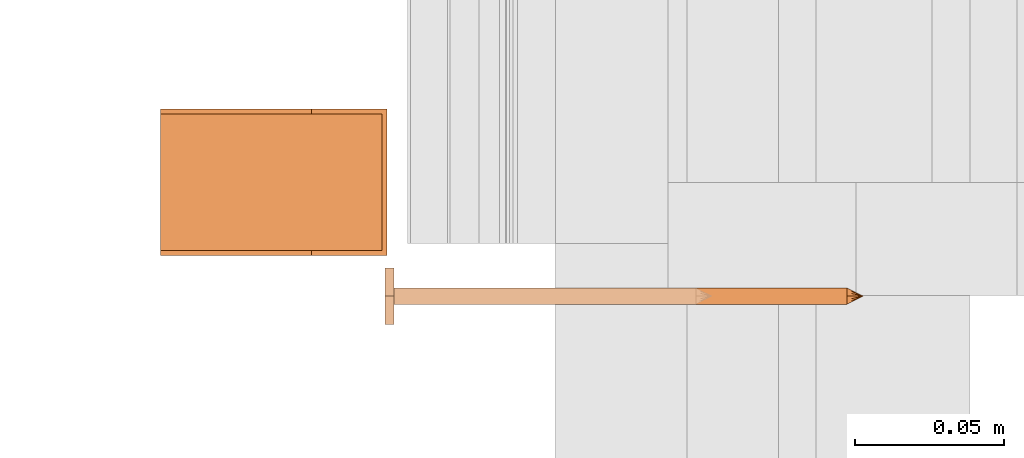
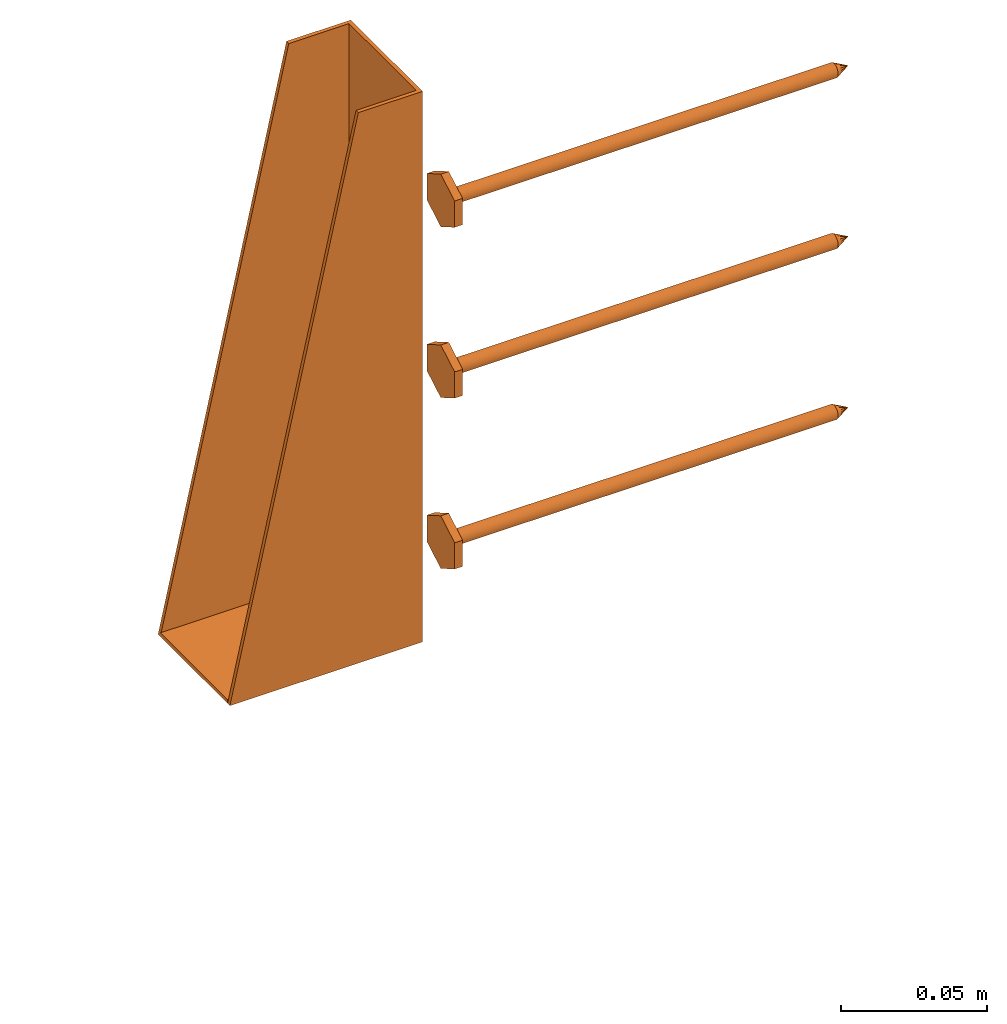
# One storey, part 18 of 44: 4 proxies.
"""IFC4 building model written with IfcOpenShell, lengths in feet."""

from ifc_helpers import new_model, entity, si_unit, converted_unit, derived_unit, direction, frame, frame_2d, origin, origin_2d_with_axis, place, context, subcontext, project, spatial, polyline, rectangle, outline, extrude, source, transform, mapped, material, type_object, type_shapes, element, save


model = new_model("IFC4")

# Units and contexts
model_context = context("Model", 3, precision=0.0001, world=origin(), true_north=direction((6.12303176911189e-17, 1.0)))
body_context = subcontext(model_context, "Body", "Model", "MODEL_VIEW")
ifc_project = project(units=[converted_unit("LENGTHUNIT", "FOOT", entity("IfcRatioMeasure", 0.3048), si_unit("LENGTHUNIT", "METRE"), dimensions=[1, 0, 0, 0, 0, 0, 0]), converted_unit("AREAUNIT", "SQUARE FOOT", entity("IfcRatioMeasure", 0.09290304), si_unit("AREAUNIT", "SQUARE_METRE"), dimensions=[2, 0, 0, 0, 0, 0, 0]), converted_unit("VOLUMEUNIT", "CUBIC FOOT", entity("IfcRatioMeasure", 0.028316846592), si_unit("VOLUMEUNIT", "CUBIC_METRE"), dimensions=[3, 0, 0, 0, 0, 0, 0]), converted_unit("PLANEANGLEUNIT", "DEGREE", entity("IfcRatioMeasure", 0.0174532925199433), si_unit("PLANEANGLEUNIT", "RADIAN"), dimensions=[0, 0, 0, 0, 0, 0, 0]), si_unit("MASSUNIT", "GRAM", prefix="KILO"), derived_unit("MASSDENSITYUNIT", [(si_unit("MASSUNIT", "GRAM", prefix="KILO"), 1), (si_unit("LENGTHUNIT", "METRE"), -3)]), derived_unit("MOMENTOFINERTIAUNIT", [(si_unit("LENGTHUNIT", "METRE"), 4)]), si_unit("TIMEUNIT", "SECOND"), si_unit("FREQUENCYUNIT", "HERTZ"), si_unit("THERMODYNAMICTEMPERATUREUNIT", "DEGREE_CELSIUS"), derived_unit("THERMALTRANSMITTANCEUNIT", [(si_unit("MASSUNIT", "GRAM", prefix="KILO"), 1), (si_unit("THERMODYNAMICTEMPERATUREUNIT", "KELVIN"), -1), (si_unit("TIMEUNIT", "SECOND"), -3)]), derived_unit("VOLUMETRICFLOWRATEUNIT", [(si_unit("LENGTHUNIT", "METRE"), 3), (si_unit("TIMEUNIT", "SECOND"), -1)]), si_unit("ELECTRICCURRENTUNIT", "AMPERE"), si_unit("ELECTRICVOLTAGEUNIT", "VOLT"), si_unit("POWERUNIT", "WATT"), si_unit("FORCEUNIT", "NEWTON"), si_unit("ILLUMINANCEUNIT", "LUX"), si_unit("LUMINOUSFLUXUNIT", "LUMEN"), si_unit("LUMINOUSINTENSITYUNIT", "CANDELA"), derived_unit("USERDEFINED", [(si_unit("MASSUNIT", "GRAM", prefix="KILO"), -1), (si_unit("LENGTHUNIT", "METRE"), -2), (si_unit("TIMEUNIT", "SECOND"), 3), (si_unit("LUMINOUSFLUXUNIT", "LUMEN"), 1)]), derived_unit("LINEARVELOCITYUNIT", [(si_unit("LENGTHUNIT", "METRE"), 1), (si_unit("TIMEUNIT", "SECOND"), -1)]), si_unit("PRESSUREUNIT", "PASCAL"), derived_unit("USERDEFINED", [(si_unit("LENGTHUNIT", "METRE"), -2), (si_unit("MASSUNIT", "GRAM", prefix="KILO"), 1), (si_unit("TIMEUNIT", "SECOND"), -2)]), derived_unit("LINEARFORCEUNIT", [(si_unit("MASSUNIT", "GRAM", prefix="KILO"), 1), (si_unit("LENGTHUNIT", "METRE"), 1), (si_unit("TIMEUNIT", "SECOND"), -2), (si_unit("LENGTHUNIT", "METRE"), -1)]), derived_unit("PLANARFORCEUNIT", [(si_unit("MASSUNIT", "GRAM", prefix="KILO"), 1), (si_unit("LENGTHUNIT", "METRE"), 1), (si_unit("TIMEUNIT", "SECOND"), -2), (si_unit("LENGTHUNIT", "METRE"), -2)])], contexts=[model_context])

# Site, building, storey
site_placement = place(None, origin())
site = spatial("IfcSite", under=ifc_project, at=site_placement, CompositionType="ELEMENT")
building_placement = place(site_placement, origin())
building = spatial("IfcBuilding", under=site, at=building_placement, CompositionType="ELEMENT")
storey_placement = place(building_placement, origin())
storey = spatial("IfcBuildingStorey", under=building, at=storey_placement, CompositionType="ELEMENT", Elevation=0.0)

# Proxies
ifc_material_1 = material(Name="HUC46 JOIST HANGER WITH CONCEALED HDG - UNPAINTED", Category="Materials")
building_element_proxy_type_1 = type_object("IfcBuildingElementProxyType", Name="050523 - Metal Joist Hanger - Generic:1.81/9-SDS", PredefinedType="NOTDEFINED", material=ifc_material_1)
shared_shape_1 = source(origin(), body_context, "Body", "SweptSolid", [
    extrude(outline(polyline([(-0.377604166666657, -0.0833333333333589), (0.377604166666657, -0.0833333333333589), (0.377604166666657, 0.0), (-0.377604166666657, 0.166666666666694), (-0.377604166666657, -0.0833333333333589)])), frame((-0.0807291666666463, -0.0833333333333328, 0.372395833333338), z_axis=(1.0, 0.0, 0.0), x_axis=(0.0, 0.0, 1.0)), (0.0, 0.0, 1.0), 0.00520833333333333),
    extrude(outline(polyline([(-0.377604166666661, -0.0833333333333546), (0.377604166666661, -0.0833333333333546), (0.377604166666661, 0.0), (-0.377604166666661, 0.166666666666692), (-0.377604166666661, -0.0833333333333546)])), frame((0.0755208333333537, -0.0833333333333374, 0.372395833333333), z_axis=(1.0, 0.0, 0.0), x_axis=(0.0, 0.0, 1.0)), (0.0, 0.0, 1.0), 0.00520833333333333),
    extrude(rectangle(XDim=0.00520833333329789, YDim=0.104166666666653, at=origin_2d_with_axis()), frame((0.0234375000000141, -0.00260416666671204, 0.0), z_axis=(0.0, 0.0, 1.0), x_axis=(0.0, 1.0, 0.0)), (0.0, 0.0, 1.0), 0.750000000000093),
    extrude(rectangle(XDim=0.00520833333329789, YDim=0.104166666666656, at=origin_2d_with_axis()), frame((-0.0234375000000063, -0.00260416666671204, 0.0), z_axis=(0.0, 0.0, 1.0), x_axis=(0.0, 1.0, 0.0)), (0.0, 0.0, 1.0), 0.750000000000097),
    extrude(rectangle(XDim=0.250000000000316, YDim=0.151041666666731, at=frame_2d((-2.77555756156289e-17, -6.93889390390723e-18), x_axis=(1.0, 0.0))), frame((0.0, -0.125000000000474, -0.00520833333333946), z_axis=(0.0, 0.0, 1.0), x_axis=(0.0, -1.0, 0.0)), (0.0, 0.0, 1.0), 0.00520833333333333),
])
type_shapes(building_element_proxy_type_1, [shared_shape_1])
proxy_placement = place(storey_placement, frame((1459.12506713878, 2.06770833332918, 31.2083333333288), z_axis=(0.0, 0.0, 1.0), x_axis=(0.0, -1.0, 0.0)))
element("IfcBuildingElementProxy", 1, at=proxy_placement, inside=storey, type_object=building_element_proxy_type_1, material=ifc_material_1, Name="050523 - Metal Joist Hanger - Generic:1.81/9", ObjectType="050523 - Metal Joist Hanger - Generic:1.81/9-SDS", PredefinedType="NOTDEFINED", context=body_context, shape_type="MappedRepresentation", body=[
    mapped(shared_shape_1, transform((0.0, 0.0, 0.0), scale=1.0)),
])
ifc_material_2 = material(Name="STRONG-DRIVE TIMBER SCREW (EXTERIOR GRADE)", Category="Materials")
building_element_proxy_type_2 = type_object("IfcBuildingElementProxyType", PredefinedType="NOTDEFINED", material=ifc_material_2)
cartesian_point_1 = entity("IfcCartesianPoint", [0.0, -0.00916666666678086, -0.499999999999898])
vertex_point_1 = entity("IfcVertexPoint", cartesian_point_1)
cartesian_point_2 = entity("IfcCartesianPoint", [0.0, 0.00916666666667654, -0.499999999999898])
vertex_point_2 = entity("IfcVertexPoint", cartesian_point_2)
cartesian_point_3 = entity("IfcCartesianPoint", [0.0, 0.0, -0.499999999999898])
ifc_direction_1 = entity("IfcDirection", [0.0, 0.0, 1.0])
ifc_direction_2 = entity("IfcDirection", [0.0, 1.0, 0.0])
edge_curve_1 = entity("IfcEdgeCurve", vertex_point_1, vertex_point_2, entity("IfcTrimmedCurve", entity("IfcCircle", entity("IfcAxis2Placement3D", cartesian_point_3, ifc_direction_1, ifc_direction_2), 0.0091666666667287), [cartesian_point_1], [cartesian_point_2], True, "CARTESIAN"), True)
vertex_point_3 = entity("IfcVertexPoint", cartesian_point_3)
ifc_direction_3 = entity("IfcDirection", [0.0, -1.0, 0.0])
edge_curve_2 = entity("IfcEdgeCurve", vertex_point_2, vertex_point_3, entity("IfcTrimmedCurve", entity("IfcLine", cartesian_point_2, entity("IfcVector", ifc_direction_3, 1.0)), [cartesian_point_2], [cartesian_point_3], True, "CARTESIAN"), True)
edge_curve_3 = entity("IfcEdgeCurve", vertex_point_3, vertex_point_1, entity("IfcTrimmedCurve", entity("IfcLine", cartesian_point_3, entity("IfcVector", ifc_direction_3, 1.0)), [cartesian_point_3], [cartesian_point_1], True, "CARTESIAN"), True)
edge_curve_4 = entity("IfcEdgeCurve", vertex_point_2, vertex_point_1, entity("IfcTrimmedCurve", entity("IfcCircle", entity("IfcAxis2Placement3D", cartesian_point_3, ifc_direction_1, ifc_direction_2), 0.0091666666667287), [cartesian_point_2], [cartesian_point_1], True, "CARTESIAN"), True)
cartesian_point_4 = entity("IfcCartesianPoint", [0.0, 0.0, -0.518333333333])
vertex_point_4 = entity("IfcVertexPoint", cartesian_point_4)
edge_curve_5 = entity("IfcEdgeCurve", vertex_point_4, vertex_point_2, entity("IfcTrimmedCurve", entity("IfcLine", cartesian_point_4, entity("IfcVector", entity("IfcDirection", [0.0, 0.447213595507238, 0.894427190996276]), 1.0)), [cartesian_point_4], [cartesian_point_2], True, "CARTESIAN"), True)
edge_curve_6 = entity("IfcEdgeCurve", vertex_point_1, vertex_point_4, entity("IfcTrimmedCurve", entity("IfcLine", cartesian_point_1, entity("IfcVector", entity("IfcDirection", [0.0, 0.447213595507224, -0.894427190996283]), 1.0)), [cartesian_point_1], [cartesian_point_4], True, "CARTESIAN"), True)
cartesian_point_5 = entity("IfcCartesianPoint", [-0.00916666666669726, 0.0, -0.499999999999898])
cartesian_point_6 = entity("IfcCartesianPoint", [0.0, 0.0, -0.504868851257523])
ifc_direction_4 = entity("IfcDirection", [0.0, 0.0, -1.0])
cartesian_point_7 = entity("IfcCartesianPoint", [-0.0312499999999625, 0.0180421959120341, 0.0104166666670403])
vertex_point_5 = entity("IfcVertexPoint", cartesian_point_7)
cartesian_point_8 = entity("IfcCartesianPoint", [-0.0312499999999625, -0.0180421959123371, 0.0104166666670405])
vertex_point_6 = entity("IfcVertexPoint", cartesian_point_8)
ifc_direction_5 = entity("IfcDirection", [0.0, -1.0, 0.0])
edge_curve_7 = entity("IfcEdgeCurve", vertex_point_5, vertex_point_6, entity("IfcTrimmedCurve", entity("IfcLine", cartesian_point_7, entity("IfcVector", ifc_direction_5, 1.0)), [cartesian_point_7], [cartesian_point_8], True, "CARTESIAN"), True)
cartesian_point_9 = entity("IfcCartesianPoint", [0.0, -0.0360843918245031, 0.0104166666670406])
vertex_point_7 = entity("IfcVertexPoint", cartesian_point_9)
edge_curve_8 = entity("IfcEdgeCurve", vertex_point_6, vertex_point_7, entity("IfcTrimmedCurve", entity("IfcLine", cartesian_point_8, entity("IfcVector", entity("IfcDirection", [0.866025403784438, -0.500000000000001, 0.0]), 1.0)), [cartesian_point_8], [cartesian_point_9], True, "CARTESIAN"), True)
cartesian_point_10 = entity("IfcCartesianPoint", [0.0312500000000785, -0.0180421959122939, 0.0104166666670405])
vertex_point_8 = entity("IfcVertexPoint", cartesian_point_10)
edge_curve_9 = entity("IfcEdgeCurve", vertex_point_7, vertex_point_8, entity("IfcTrimmedCurve", entity("IfcLine", cartesian_point_9, entity("IfcVector", entity("IfcDirection", [0.86602540378444, 0.499999999999998, 0.0]), 1.0)), [cartesian_point_9], [cartesian_point_10], True, "CARTESIAN"), True)
cartesian_point_11 = entity("IfcCartesianPoint", [0.0312500000000786, 0.0180421959119906, 0.0104166666670403])
vertex_point_9 = entity("IfcVertexPoint", cartesian_point_11)
ifc_direction_6 = entity("IfcDirection", [0.0, 1.0, 0.0])
edge_curve_10 = entity("IfcEdgeCurve", vertex_point_8, vertex_point_9, entity("IfcTrimmedCurve", entity("IfcLine", cartesian_point_10, entity("IfcVector", ifc_direction_6, 1.0)), [cartesian_point_10], [cartesian_point_11], True, "CARTESIAN"), True)
cartesian_point_12 = entity("IfcCartesianPoint", [0.0, 0.0360843918242001, 0.0104166666670402])
vertex_point_10 = entity("IfcVertexPoint", cartesian_point_12)
edge_curve_11 = entity("IfcEdgeCurve", vertex_point_9, vertex_point_10, entity("IfcTrimmedCurve", entity("IfcLine", cartesian_point_11, entity("IfcVector", entity("IfcDirection", [-0.866025403784436, 0.500000000000004, 0.0]), 1.0)), [cartesian_point_11], [cartesian_point_12], True, "CARTESIAN"), True)
edge_curve_12 = entity("IfcEdgeCurve", vertex_point_10, vertex_point_5, entity("IfcTrimmedCurve", entity("IfcLine", cartesian_point_12, entity("IfcVector", entity("IfcDirection", [-0.866025403784438, -0.500000000000001, 0.0]), 1.0)), [cartesian_point_12], [cartesian_point_7], True, "CARTESIAN"), True)
ifc_direction_7 = entity("IfcDirection", [0.0, 0.0, 1.0])
cartesian_point_13 = entity("IfcCartesianPoint", [-0.0312499999999625, 0.018042195912034, 0.0])
vertex_point_11 = entity("IfcVertexPoint", cartesian_point_13)
cartesian_point_14 = entity("IfcCartesianPoint", [0.0, 0.0360843918242001, 0.0])
vertex_point_12 = entity("IfcVertexPoint", cartesian_point_14)
edge_curve_13 = entity("IfcEdgeCurve", vertex_point_11, vertex_point_12, entity("IfcTrimmedCurve", entity("IfcLine", cartesian_point_13, entity("IfcVector", entity("IfcDirection", [0.866025403784438, 0.500000000000001, 0.0]), 1.0)), [cartesian_point_13], [cartesian_point_14], True, "CARTESIAN"), True)
cartesian_point_15 = entity("IfcCartesianPoint", [0.0312500000000786, 0.0180421959119905, 0.0])
vertex_point_13 = entity("IfcVertexPoint", cartesian_point_15)
edge_curve_14 = entity("IfcEdgeCurve", vertex_point_12, vertex_point_13, entity("IfcTrimmedCurve", entity("IfcLine", cartesian_point_14, entity("IfcVector", entity("IfcDirection", [0.866025403784437, -0.500000000000004, 0.0]), 1.0)), [cartesian_point_14], [cartesian_point_15], True, "CARTESIAN"), True)
cartesian_point_16 = entity("IfcCartesianPoint", [0.0312500000000785, -0.0180421959122939, 0.0])
vertex_point_14 = entity("IfcVertexPoint", cartesian_point_16)
edge_curve_15 = entity("IfcEdgeCurve", vertex_point_13, vertex_point_14, entity("IfcTrimmedCurve", entity("IfcLine", cartesian_point_15, entity("IfcVector", ifc_direction_5, 1.0)), [cartesian_point_15], [cartesian_point_16], True, "CARTESIAN"), True)
cartesian_point_17 = entity("IfcCartesianPoint", [0.0, -0.0360843918245032, 0.0])
vertex_point_15 = entity("IfcVertexPoint", cartesian_point_17)
edge_curve_16 = entity("IfcEdgeCurve", vertex_point_14, vertex_point_15, entity("IfcTrimmedCurve", entity("IfcLine", cartesian_point_16, entity("IfcVector", entity("IfcDirection", [-0.86602540378444, -0.499999999999998, 0.0]), 1.0)), [cartesian_point_16], [cartesian_point_17], True, "CARTESIAN"), True)
cartesian_point_18 = entity("IfcCartesianPoint", [-0.0312499999999625, -0.0180421959123372, 0.0])
vertex_point_16 = entity("IfcVertexPoint", cartesian_point_18)
edge_curve_17 = entity("IfcEdgeCurve", vertex_point_15, vertex_point_16, entity("IfcTrimmedCurve", entity("IfcLine", cartesian_point_17, entity("IfcVector", entity("IfcDirection", [-0.866025403784438, 0.500000000000001, 0.0]), 1.0)), [cartesian_point_17], [cartesian_point_18], True, "CARTESIAN"), True)
edge_curve_18 = entity("IfcEdgeCurve", vertex_point_16, vertex_point_11, entity("IfcTrimmedCurve", entity("IfcLine", cartesian_point_18, entity("IfcVector", ifc_direction_6, 1.0)), [cartesian_point_18], [cartesian_point_13], True, "CARTESIAN"), True)
ifc_direction_8 = entity("IfcDirection", [0.0, 0.0, -1.0])
edge_curve_19 = entity("IfcEdgeCurve", vertex_point_5, vertex_point_11, entity("IfcTrimmedCurve", entity("IfcLine", cartesian_point_7, entity("IfcVector", ifc_direction_8, 1.0)), [cartesian_point_7], [cartesian_point_13], True, "CARTESIAN"), True)
edge_curve_20 = entity("IfcEdgeCurve", vertex_point_16, vertex_point_6, entity("IfcTrimmedCurve", entity("IfcLine", cartesian_point_8, entity("IfcVector", ifc_direction_7, 1.0)), [cartesian_point_18], [cartesian_point_8], True, "CARTESIAN"), True)
edge_curve_21 = entity("IfcEdgeCurve", vertex_point_15, vertex_point_7, entity("IfcTrimmedCurve", entity("IfcLine", cartesian_point_9, entity("IfcVector", ifc_direction_7, 1.0)), [cartesian_point_17], [cartesian_point_9], True, "CARTESIAN"), True)
edge_curve_22 = entity("IfcEdgeCurve", vertex_point_14, vertex_point_8, entity("IfcTrimmedCurve", entity("IfcLine", cartesian_point_10, entity("IfcVector", ifc_direction_7, 1.0)), [cartesian_point_16], [cartesian_point_10], True, "CARTESIAN"), True)
edge_curve_23 = entity("IfcEdgeCurve", vertex_point_13, vertex_point_9, entity("IfcTrimmedCurve", entity("IfcLine", cartesian_point_11, entity("IfcVector", ifc_direction_7, 1.0)), [cartesian_point_15], [cartesian_point_11], True, "CARTESIAN"), True)
edge_curve_24 = entity("IfcEdgeCurve", vertex_point_12, vertex_point_10, entity("IfcTrimmedCurve", entity("IfcLine", cartesian_point_12, entity("IfcVector", ifc_direction_7, 1.0)), [cartesian_point_14], [cartesian_point_12], True, "CARTESIAN"), True)
cartesian_point_19 = entity("IfcCartesianPoint", [0.0, -0.00916666666682102, 0.0])
vertex_point_17 = entity("IfcVertexPoint", cartesian_point_19)
cartesian_point_20 = entity("IfcCartesianPoint", [0.0, 0.00916666666651231, 0.0])
vertex_point_18 = entity("IfcVertexPoint", cartesian_point_20)
cartesian_point_21 = entity("IfcCartesianPoint", [0.0, 0.0, 0.0])
ifc_direction_9 = entity("IfcDirection", [0.0, 0.0, 1.0])
ifc_direction_10 = entity("IfcDirection", [0.0, 1.0, 0.0])
edge_curve_25 = entity("IfcEdgeCurve", vertex_point_17, vertex_point_18, entity("IfcTrimmedCurve", entity("IfcCircle", entity("IfcAxis2Placement3D", cartesian_point_21, ifc_direction_9, ifc_direction_10), 0.00916666666666667), [cartesian_point_19], [cartesian_point_20], True, "CARTESIAN"), True)
edge_curve_26 = entity("IfcEdgeCurve", vertex_point_18, vertex_point_17, entity("IfcTrimmedCurve", entity("IfcCircle", entity("IfcAxis2Placement3D", cartesian_point_21, ifc_direction_9, ifc_direction_10), 0.00916666666666667), [cartesian_point_20], [cartesian_point_19], True, "CARTESIAN"), True)
cartesian_point_22 = entity("IfcCartesianPoint", [0.0, -0.00916666666682533, -0.500000000000006])
vertex_point_19 = entity("IfcVertexPoint", cartesian_point_22)
cartesian_point_23 = entity("IfcCartesianPoint", [0.0, 0.00916666666650801, -0.500000000000006])
vertex_point_20 = entity("IfcVertexPoint", cartesian_point_23)
cartesian_point_24 = entity("IfcCartesianPoint", [0.0, 0.0, -0.500000000000006])
ifc_direction_11 = entity("IfcDirection", [0.0, 0.0, -1.0])
edge_curve_27 = entity("IfcEdgeCurve", vertex_point_19, vertex_point_20, entity("IfcTrimmedCurve", entity("IfcCircle", entity("IfcAxis2Placement3D", cartesian_point_24, ifc_direction_11, ifc_direction_10), 0.00916666666666667), [cartesian_point_22], [cartesian_point_23], True, "CARTESIAN"), True)
edge_curve_28 = entity("IfcEdgeCurve", vertex_point_20, vertex_point_19, entity("IfcTrimmedCurve", entity("IfcCircle", entity("IfcAxis2Placement3D", cartesian_point_24, ifc_direction_11, ifc_direction_10), 0.00916666666666667), [cartesian_point_23], [cartesian_point_22], True, "CARTESIAN"), True)
edge_curve_29 = entity("IfcEdgeCurve", vertex_point_17, vertex_point_19, entity("IfcTrimmedCurve", entity("IfcLine", cartesian_point_19, entity("IfcVector", ifc_direction_11, 1.0)), [cartesian_point_19], [cartesian_point_22], True, "CARTESIAN"), True)
edge_curve_30 = entity("IfcEdgeCurve", vertex_point_20, vertex_point_18, entity("IfcTrimmedCurve", entity("IfcLine", cartesian_point_20, entity("IfcVector", ifc_direction_9, 1.0)), [cartesian_point_23], [cartesian_point_20], True, "CARTESIAN"), True)
shared_shape_2 = source(origin(), body_context, "Body", "AdvancedBrep", [
    entity("IfcAdvancedBrep", entity("IfcClosedShell", [entity("IfcAdvancedFace", [entity("IfcFaceOuterBound", entity("IfcEdgeLoop", [entity("IfcOrientedEdge", None, None, edge_curve_1, True), entity("IfcOrientedEdge", None, None, edge_curve_2, True), entity("IfcOrientedEdge", None, None, edge_curve_3, True)]), True)], entity("IfcPlane", entity("IfcAxis2Placement3D", cartesian_point_3, ifc_direction_1, ifc_direction_2)), True), entity("IfcAdvancedFace", [entity("IfcFaceOuterBound", entity("IfcEdgeLoop", [entity("IfcOrientedEdge", None, None, edge_curve_4, True), entity("IfcOrientedEdge", None, None, edge_curve_3, False), entity("IfcOrientedEdge", None, None, edge_curve_2, False)]), True)], entity("IfcPlane", entity("IfcAxis2Placement3D", cartesian_point_3, ifc_direction_1, ifc_direction_2)), True), entity("IfcAdvancedFace", [entity("IfcFaceOuterBound", entity("IfcEdgeLoop", [entity("IfcOrientedEdge", None, None, edge_curve_5, True), entity("IfcOrientedEdge", None, None, edge_curve_1, False), entity("IfcOrientedEdge", None, None, edge_curve_6, True)]), True)], entity("IfcSurfaceOfRevolution", entity("IfcArbitraryOpenProfileDef", "CURVE", None, entity("IfcTrimmedCurve", entity("IfcLine", cartesian_point_4, entity("IfcVector", entity("IfcDirection", [0.447213595507221, 0.0, -0.894427190996284]), 1.0)), [cartesian_point_5], [cartesian_point_4], True, "CARTESIAN")), None, entity("IfcAxis1Placement", cartesian_point_6, ifc_direction_4)), True), entity("IfcAdvancedFace", [entity("IfcFaceOuterBound", entity("IfcEdgeLoop", [entity("IfcOrientedEdge", None, None, edge_curve_6, False), entity("IfcOrientedEdge", None, None, edge_curve_4, False), entity("IfcOrientedEdge", None, None, edge_curve_5, False)]), True)], entity("IfcSurfaceOfRevolution", entity("IfcArbitraryOpenProfileDef", "CURVE", None, entity("IfcTrimmedCurve", entity("IfcLine", cartesian_point_4, entity("IfcVector", entity("IfcDirection", [0.447213595507221, 0.0, -0.894427190996284]), 1.0)), [cartesian_point_5], [cartesian_point_4], True, "CARTESIAN")), None, entity("IfcAxis1Placement", cartesian_point_6, ifc_direction_4)), True)])),
    entity("IfcAdvancedBrep", entity("IfcClosedShell", [entity("IfcAdvancedFace", [entity("IfcFaceOuterBound", entity("IfcEdgeLoop", [entity("IfcOrientedEdge", None, None, edge_curve_7, True), entity("IfcOrientedEdge", None, None, edge_curve_8, True), entity("IfcOrientedEdge", None, None, edge_curve_9, True), entity("IfcOrientedEdge", None, None, edge_curve_10, True), entity("IfcOrientedEdge", None, None, edge_curve_11, True), entity("IfcOrientedEdge", None, None, edge_curve_12, True)]), True)], entity("IfcPlane", entity("IfcAxis2Placement3D", cartesian_point_7, ifc_direction_7, ifc_direction_5)), True), entity("IfcAdvancedFace", [entity("IfcFaceOuterBound", entity("IfcEdgeLoop", [entity("IfcOrientedEdge", None, None, edge_curve_13, True), entity("IfcOrientedEdge", None, None, edge_curve_14, True), entity("IfcOrientedEdge", None, None, edge_curve_15, True), entity("IfcOrientedEdge", None, None, edge_curve_16, True), entity("IfcOrientedEdge", None, None, edge_curve_17, True), entity("IfcOrientedEdge", None, None, edge_curve_18, True)]), True)], entity("IfcPlane", entity("IfcAxis2Placement3D", cartesian_point_13, ifc_direction_8, ifc_direction_6)), True), entity("IfcAdvancedFace", [entity("IfcFaceOuterBound", entity("IfcEdgeLoop", [entity("IfcOrientedEdge", None, None, edge_curve_7, False), entity("IfcOrientedEdge", None, None, edge_curve_19, True), entity("IfcOrientedEdge", None, None, edge_curve_18, False), entity("IfcOrientedEdge", None, None, edge_curve_20, True)]), True)], entity("IfcPlane", entity("IfcAxis2Placement3D", cartesian_point_7, entity("IfcDirection", [-1.0, 0.0, 0.0]), ifc_direction_8)), True), entity("IfcAdvancedFace", [entity("IfcFaceOuterBound", entity("IfcEdgeLoop", [entity("IfcOrientedEdge", None, None, edge_curve_8, False), entity("IfcOrientedEdge", None, None, edge_curve_20, False), entity("IfcOrientedEdge", None, None, edge_curve_17, False), entity("IfcOrientedEdge", None, None, edge_curve_21, True)]), True)], entity("IfcPlane", entity("IfcAxis2Placement3D", cartesian_point_8, entity("IfcDirection", [-0.500000000000001, -0.866025403784438, 0.0]), ifc_direction_8)), True), entity("IfcAdvancedFace", [entity("IfcFaceOuterBound", entity("IfcEdgeLoop", [entity("IfcOrientedEdge", None, None, edge_curve_9, False), entity("IfcOrientedEdge", None, None, edge_curve_21, False), entity("IfcOrientedEdge", None, None, edge_curve_16, False), entity("IfcOrientedEdge", None, None, edge_curve_22, True)]), True)], entity("IfcPlane", entity("IfcAxis2Placement3D", cartesian_point_9, entity("IfcDirection", [0.499999999999998, -0.86602540378444, 0.0]), ifc_direction_8)), True), entity("IfcAdvancedFace", [entity("IfcFaceOuterBound", entity("IfcEdgeLoop", [entity("IfcOrientedEdge", None, None, edge_curve_10, False), entity("IfcOrientedEdge", None, None, edge_curve_22, False), entity("IfcOrientedEdge", None, None, edge_curve_15, False), entity("IfcOrientedEdge", None, None, edge_curve_23, True)]), True)], entity("IfcPlane", entity("IfcAxis2Placement3D", cartesian_point_10, entity("IfcDirection", [1.0, 0.0, 0.0]), ifc_direction_8)), True), entity("IfcAdvancedFace", [entity("IfcFaceOuterBound", entity("IfcEdgeLoop", [entity("IfcOrientedEdge", None, None, edge_curve_11, False), entity("IfcOrientedEdge", None, None, edge_curve_23, False), entity("IfcOrientedEdge", None, None, edge_curve_14, False), entity("IfcOrientedEdge", None, None, edge_curve_24, True)]), True)], entity("IfcPlane", entity("IfcAxis2Placement3D", cartesian_point_11, entity("IfcDirection", [0.500000000000003, 0.866025403784437, 0.0]), ifc_direction_8)), True), entity("IfcAdvancedFace", [entity("IfcFaceOuterBound", entity("IfcEdgeLoop", [entity("IfcOrientedEdge", None, None, edge_curve_12, False), entity("IfcOrientedEdge", None, None, edge_curve_24, False), entity("IfcOrientedEdge", None, None, edge_curve_13, False), entity("IfcOrientedEdge", None, None, edge_curve_19, False)]), True)], entity("IfcPlane", entity("IfcAxis2Placement3D", cartesian_point_12, entity("IfcDirection", [-0.500000000000001, 0.866025403784438, 0.0]), ifc_direction_8)), True)])),
    entity("IfcAdvancedBrep", entity("IfcClosedShell", [entity("IfcAdvancedFace", [entity("IfcFaceOuterBound", entity("IfcEdgeLoop", [entity("IfcOrientedEdge", None, None, edge_curve_25, True), entity("IfcOrientedEdge", None, None, edge_curve_26, True)]), True)], entity("IfcPlane", entity("IfcAxis2Placement3D", cartesian_point_20, ifc_direction_9, entity("IfcDirection", [-1.0, 0.0, 0.0]))), True), entity("IfcAdvancedFace", [entity("IfcFaceOuterBound", entity("IfcEdgeLoop", [entity("IfcOrientedEdge", None, None, edge_curve_27, True), entity("IfcOrientedEdge", None, None, edge_curve_28, True)]), True)], entity("IfcPlane", entity("IfcAxis2Placement3D", cartesian_point_23, ifc_direction_11, entity("IfcDirection", [1.0, 0.0, 0.0]))), True), entity("IfcAdvancedFace", [entity("IfcFaceOuterBound", entity("IfcEdgeLoop", [entity("IfcOrientedEdge", None, None, edge_curve_25, False), entity("IfcOrientedEdge", None, None, edge_curve_29, True), entity("IfcOrientedEdge", None, None, edge_curve_28, False), entity("IfcOrientedEdge", None, None, edge_curve_30, True)]), True)], entity("IfcCylindricalSurface", entity("IfcAxis2Placement3D", cartesian_point_24, ifc_direction_9, ifc_direction_10), 0.00916666666666667), True), entity("IfcAdvancedFace", [entity("IfcFaceOuterBound", entity("IfcEdgeLoop", [entity("IfcOrientedEdge", None, None, edge_curve_26, False), entity("IfcOrientedEdge", None, None, edge_curve_30, False), entity("IfcOrientedEdge", None, None, edge_curve_27, False), entity("IfcOrientedEdge", None, None, edge_curve_29, False)]), True)], entity("IfcCylindricalSurface", entity("IfcAxis2Placement3D", cartesian_point_24, ifc_direction_9, ifc_direction_10), 0.00916666666666667), True)])),
])
type_shapes(building_element_proxy_type_2, [shared_shape_2])
for number, where, z_axis, x_axis in (
    (2, (1459.13314342118, 1.94204634015959, 31.3680531400706), (-1.0, 0.0, 0.0), (0.0, 1.0, 0.0)),
    (3, (1459.13314342118, 1.94204634015959, 31.8368031400706), (-1.0, 0.0, 0.0), (0.0, 1.0, 0.0)),
    (4, (1459.13314342118, 1.94204634015959, 31.6024281400706), (-1.0, 0.0, 0.0), (0.0, 1.0, 0.0)),
):
    element("IfcBuildingElementProxy", number, at=place(storey_placement, frame(where, z_axis=z_axis, x_axis=x_axis)), inside=storey, type_object=building_element_proxy_type_2, material=ifc_material_2, PredefinedType="NOTDEFINED", context=body_context, shape_type="MappedRepresentation", body=[
        mapped(shared_shape_2, transform((0.0, 0.0, 0.0), scale=1.0)),
    ])

save(model, "model.ifc")
